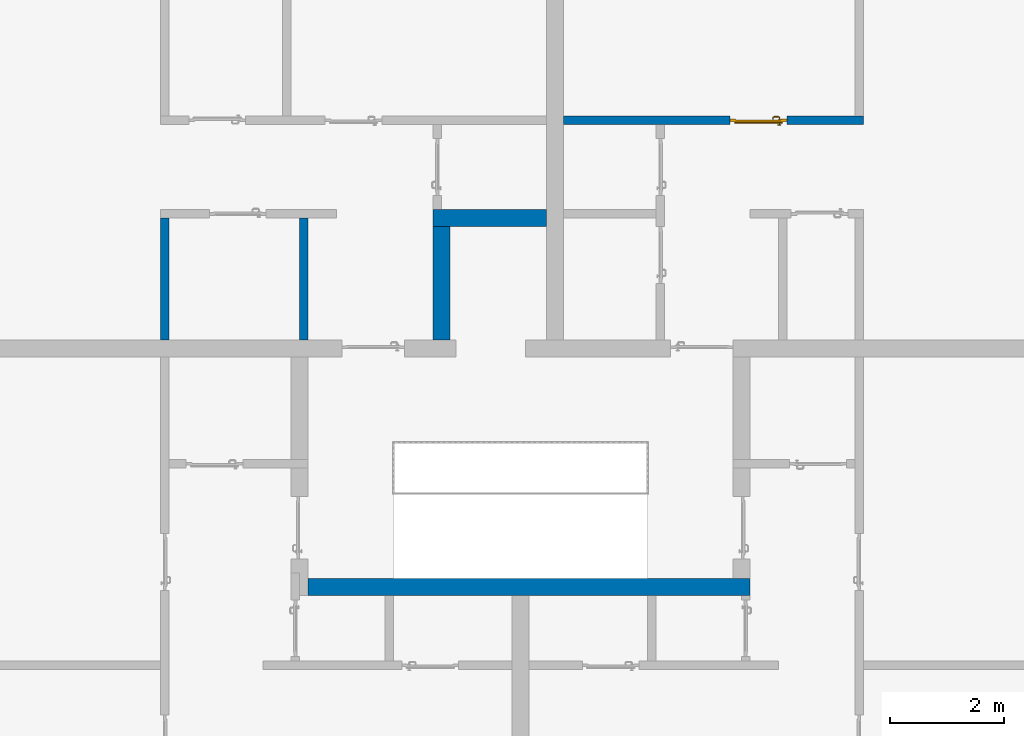
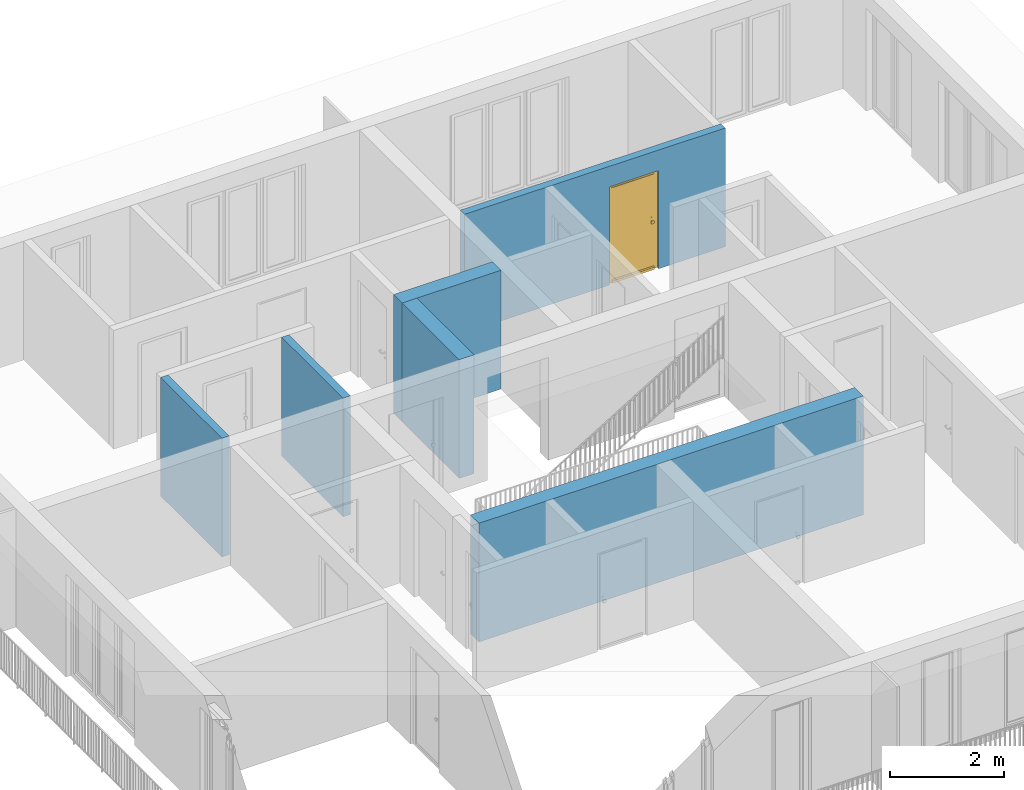
# One storey, part 29 of 54: 6 walls, 1 door, 1 opening.
"""IFC4 building model written with IfcOpenShell, lengths in metres."""

from ifc_helpers import new_model, entity, si_unit, converted_unit, derived_unit, direction, frame, origin_with_axes, place, context, subcontext, project, spatial, polygons, source, transform, mapped, material, type_object, element, fill, save


model = new_model("IFC4")

# Units and contexts
model_context = context("Model", 3, precision=1e-05, world=origin_with_axes(), true_north=direction((0.0, 1.0)))
body_context = subcontext(model_context, "Body", "Model", "MODEL_VIEW")
ifc_project = project(units=[si_unit("LENGTHUNIT", "METRE"), si_unit("AREAUNIT", "SQUARE_METRE"), si_unit("VOLUMEUNIT", "CUBIC_METRE"), converted_unit("PLANEANGLEUNIT", "DEGREE", entity("IfcPlaneAngleMeasure", 0.0174532925199), si_unit("PLANEANGLEUNIT", "RADIAN"), dimensions=[0, 0, 0, 0, 0, 0, 0]), converted_unit("TIMEUNIT", "Year", entity("IfcTimeMeasure", 31556926.0), si_unit("TIMEUNIT", "SECOND"), dimensions=[0, 0, 1, 0, 0, 0, 0]), si_unit("MASSUNIT", "GRAM", prefix="KILO"), si_unit("THERMODYNAMICTEMPERATUREUNIT", "DEGREE_CELSIUS"), si_unit("LUMINOUSINTENSITYUNIT", "LUMEN"), si_unit("ENERGYUNIT", "JOULE", prefix="MEGA"), derived_unit("THERMALCONDUCTANCEUNIT", [(si_unit("POWERUNIT", "WATT"), 1), (si_unit("LENGTHUNIT", "METRE"), -1), (si_unit("THERMODYNAMICTEMPERATUREUNIT", "KELVIN"), -1)]), derived_unit("SPECIFICHEATCAPACITYUNIT", [(si_unit("ENERGYUNIT", "JOULE"), 1), (si_unit("MASSUNIT", "GRAM", prefix="KILO"), -1), (si_unit("THERMODYNAMICTEMPERATUREUNIT", "KELVIN"), -1)]), derived_unit("MASSDENSITYUNIT", [(si_unit("MASSUNIT", "GRAM", prefix="KILO"), 1), (si_unit("VOLUMEUNIT", "CUBIC_METRE"), -1)])], contexts=[model_context])

# Site, building, storey
site_placement = place(None, origin_with_axes())
site = spatial("IfcSite", under=ifc_project, at=site_placement, CompositionType="ELEMENT")
building_placement = place(site_placement, origin_with_axes())
building = spatial("IfcBuilding", under=site, at=building_placement, CompositionType="ELEMENT")
storey_placement = place(building_placement, frame((0.0, 0.0, 6.29), z_axis=(0.0, 0.0, 1.0), x_axis=(1.0, 0.0, 0.0)))
storey = spatial("IfcBuildingStorey", under=building, at=storey_placement, Name="2. Geschoss", CompositionType="ELEMENT", Elevation=6.29)

# Walls
ifc_material = material()
wall_type_1 = type_object("IfcWallType", Name="300", PredefinedType="NOTDEFINED")
wall_1_placement = place(storey_placement, frame((2.8378006196, -2.52881223104, 0.0), z_axis=(0.0, 0.0, 1.0), x_axis=(-1.0, 0.0, 0.0)))
element("IfcWall", 1, at=wall_1_placement, inside=storey, type_object=wall_type_1, material=ifc_material, Name="Wand-001", PredefinedType="NOTDEFINED", context=body_context, shape_type="Tessellation", body=[
    polygons([(7.78, 0.0, 2.54), (6.28, 0.0, 2.54), (1.8, 0.0, 2.54), (0.0, 0.0, 2.54), (0.0, 0.0, 0.0), (7.78, 0.0, 0.0), (7.78, 0.3, 2.54), (0.0, 0.3, 2.54), (0.0, 0.3, 0.0), (7.78, 0.3, 0.0)], [[[1, 2, 3, 4, 5, 6]], [[4, 3, 2, 1, 7, 8]], [[5, 4, 8, 9]], [[5, 9, 10, 6]], [[10, 7, 1, 6]], [[8, 7, 10, 9]]], closed=True),
])
wall_2_placement = place(storey_placement, frame((-2.7421993804, 3.67118776896, 0.0), z_axis=(0.0, 0.0, 1.0), x_axis=(1.0, 0.0, 0.0)))
element("IfcWall", 2, at=wall_2_placement, inside=storey, type_object=wall_type_1, material=ifc_material, Name="Wand-001", PredefinedType="NOTDEFINED", context=body_context, shape_type="Tessellation", body=[
    polygons([(0.0, 0.3, 0.0), (0.0, 0.3, 2.54), (2.0, 0.3, 2.54), (2.0, 0.3, 0.0), (0.0, 0.0, 0.0), (0.0, 0.0, 2.54), (2.0, 0.0, 2.54), (2.0, 0.0, 0.0)], [[[1, 2, 3, 4]], [[5, 6, 2, 1]], [[6, 7, 3, 2]], [[4, 3, 7, 8]], [[5, 1, 4, 8]], [[8, 7, 6, 5]]], closed=True),
])
wall_3_placement = place(storey_placement, frame((-2.7421993804, 1.37118776896, 0.0), z_axis=(0.0, 0.0, 1.0), x_axis=(0.0, 1.0, 0.0)))
element("IfcWall", 3, at=wall_3_placement, inside=storey, type_object=wall_type_1, material=ifc_material, Name="Wand-001", PredefinedType="NOTDEFINED", context=body_context, shape_type="Tessellation", body=[
    polygons([(2.3, 0.0, 0.0), (2.3, 0.0, 2.54), (2.3, -0.3, 2.54), (2.3, -0.3, 0.0), (0.3, 0.0, 0.0), (0.3, 0.0, 2.54), (0.3, -0.3, 2.54), (0.3, -0.3, 0.0)], [[[1, 2, 3, 4]], [[5, 6, 2, 1]], [[6, 7, 3, 2]], [[4, 3, 7, 8]], [[5, 1, 4, 8]], [[8, 7, 6, 5]]], closed=True),
])
wall_type_2 = type_object("IfcWallType", Name="150", PredefinedType="NOTDEFINED")
wall_4_placement = place(storey_placement, frame((-4.9421993804, 1.37118776896, 0.0), z_axis=(0.0, 0.0, 1.0), x_axis=(0.0, 1.0, 0.0)))
element("IfcWall", 4, at=wall_4_placement, inside=storey, type_object=wall_type_2, material=ifc_material, Name="Wand-002", PredefinedType="NOTDEFINED", context=body_context, shape_type="Tessellation", body=[
    polygons([(2.45, 0.15, 0.0), (2.45, 0.15, 2.54), (2.45, 0.0, 2.54), (2.45, 0.0, 0.0), (0.3, 0.15, 0.0), (0.3, 0.15, 2.54), (0.3, 0.0, 2.54), (0.3, 0.0, 0.0)], [[[1, 2, 3, 4]], [[5, 6, 2, 1]], [[6, 7, 3, 2]], [[4, 3, 7, 8]], [[5, 1, 4, 8]], [[8, 7, 6, 5]]], closed=True),
])
wall_5_placement = place(storey_placement, frame((-7.5421993804, 3.97118776896, 0.0), z_axis=(0.0, 0.0, 1.0), x_axis=(0.0, -1.0, 0.0)))
element("IfcWall", 5, at=wall_5_placement, inside=storey, type_object=wall_type_2, material=ifc_material, Name="Wand-003", PredefinedType="NOTDEFINED", context=body_context, shape_type="Tessellation", body=[
    polygons([(0.15, 0.0, 0.0), (0.15, 0.0, 2.54), (0.15, 0.15, 2.54), (0.15, 0.15, 0.0), (2.3, 0.0, 0.0), (2.3, 0.0, 2.54), (2.3, 0.15, 2.54), (2.3, 0.15, 0.0)], [[[1, 2, 3, 4]], [[5, 6, 2, 1]], [[6, 7, 3, 2]], [[4, 3, 7, 8]], [[1, 4, 8, 5]], [[8, 7, 6, 5]]], closed=True),
])

# Wall, opening, door
wall_6_placement = place(storey_placement, frame((-0.742199380397, 5.47118776896, 0.0), z_axis=(0.0, 0.0, 1.0), x_axis=(1.0, 0.0, 0.0)))
wall_6 = element("IfcWall", 6, at=wall_6_placement, inside=storey, type_object=wall_type_2, material=ifc_material, Name="Wand-002", PredefinedType="NOTDEFINED", context=body_context, shape_type="Tessellation", body=[
    polygons([(3.23, 0.15, 2.1), (3.23, 0.15, 0.0), (0.3, 0.15, 0.0), (0.3, 0.15, 2.54), (5.58, 0.15, 2.54), (5.58, 0.15, 0.0), (4.23, 0.15, 0.0), (4.23, 0.15, 2.1), (3.23, 0.05, 2.1), (3.23, 0.05, 0.0), (3.23, 0.0, 0.0), (0.3, 0.0, 0.0), (0.3, 0.0, 2.54), (5.58, 0.0, 2.54), (5.58, 0.0, 0.0), (4.23, 0.05, 0.0), (4.23, 0.0, 0.0), (4.23, 0.05, 2.1), (3.23, 0.0, 2.1), (4.23, 0.0, 2.1)], [[[1, 2, 3, 4, 5, 6, 7, 8]], [[2, 1, 9, 10]], [[2, 10, 11, 12, 3]], [[4, 3, 12, 13]], [[5, 4, 13, 14]], [[14, 15, 6, 5]], [[16, 7, 6, 15, 17]], [[8, 7, 16, 18]], [[1, 8, 18, 9]], [[10, 9, 19, 11]], [[12, 11, 19, 20, 17, 15, 14, 13]], [[18, 16, 17, 20]], [[9, 18, 20, 19]]], closed=True),
])
opening_placement = place(wall_6_placement, frame((3.73, 0.0, 0.0), z_axis=(0.0, 0.0, 1.0), x_axis=(1.0, 0.0, 0.0)))
opening = element("IfcOpeningElement", 7, at=opening_placement, cuts=wall_6, context=body_context, identifier="Reference", shape_type="Tessellation", body=[
    polygons([(0.5, 0.05, 0.0), (0.5, 0.05, 2.1), (0.5, -0.001, 2.1), (0.5, -0.001, 0.0), (0.5, 0.151, 0.0), (0.5, 0.151, 2.1), (-0.5, 0.05, 2.1), (-0.5, -0.001, 2.1), (-0.5, 0.151, 2.1), (-0.5, -0.001, 0.0), (-0.5, 0.05, 0.0), (-0.5, 0.151, 0.0)], [[[1, 2, 3, 4]], [[2, 1, 5, 6]], [[7, 8, 3, 2, 6, 9]], [[8, 10, 4, 3]], [[1, 4, 10, 11, 12, 5]], [[6, 5, 12, 9]], [[7, 11, 10, 8]], [[11, 7, 9, 12]]], closed=True),
])
door_type = type_object("IfcDoorType", Name="Eingang 01 1-Fl 26", OperationType="SINGLE_SWING_RIGHT", PredefinedType="DOOR")
shared_shape = source(origin_with_axes(), body_context, "Body", "Tessellation", [
    polygons([(0.5, -0.05, 0.0), (0.5, -0.03, 0.0), (0.5, -0.03, 2.1), (0.5, -0.05, 2.1), (0.4, -0.05, 0.0), (0.4, -0.03, 0.0), (0.4, -0.03, 2.0), (0.1301, -0.03, 2.0), (0.0001, -0.03, 2.0), (-0.4, -0.03, 2.0), (-0.4, -0.03, 0.0), (-0.5, -0.03, 0.0), (-0.5, -0.03, 2.1), (-0.5, -0.05, 2.1), (-0.5, -0.05, 0.0), (-0.4, -0.05, 0.0), (-0.4, -0.05, 2.0), (0.0001, -0.05, 2.0), (0.1301, -0.05, 2.0), (0.4, -0.05, 2.0)], [[[1, 2, 3, 4]], [[5, 6, 2, 1]], [[2, 6, 7, 8, 9, 10, 11, 12, 13, 3]], [[4, 3, 13, 14]], [[1, 4, 14, 15, 16, 17, 18, 19, 20, 5]], [[20, 7, 6, 5]], [[19, 8, 7, 20]], [[18, 9, 8, 19]], [[17, 10, 9, 18]], [[16, 11, 10, 17]], [[15, 12, 11, 16]], [[14, 13, 12, 15]]], closed=True),
    polygons([(0.5, -0.03, 0.0), (0.5, 0.0, 0.0), (0.5, 0.0, 2.1), (0.5, -0.03, 2.1), (0.43, -0.03, 0.0), (0.43, 0.0, 0.0), (0.43, 0.0, 2.03), (0.1001, 0.0, 2.03), (0.0301, 0.0, 2.03), (-0.43, 0.0, 2.03), (-0.43, 0.0, 0.0), (-0.5, 0.0, 0.0), (-0.5, 0.0, 2.1), (-0.5, -0.03, 2.1), (-0.5, -0.03, 0.0), (-0.43, -0.03, 0.0), (-0.43, -0.03, 2.03), (0.0301, -0.03, 2.03), (0.1001, -0.03, 2.03), (0.43, -0.03, 2.03)], [[[1, 2, 3, 4]], [[5, 6, 2, 1]], [[2, 6, 7, 8, 9, 10, 11, 12, 13, 3]], [[4, 3, 13, 14]], [[1, 4, 14, 15, 16, 17, 18, 19, 20, 5]], [[20, 7, 6, 5]], [[19, 8, 7, 20]], [[18, 9, 8, 19]], [[17, 10, 9, 18]], [[16, 11, 10, 17]], [[15, 12, 11, 16]], [[14, 13, 12, 15]]], closed=True),
    polygons([(0.43, 0.01, 0.0), (-0.43, 0.01, 0.0), (-0.43, 0.01, 2.03), (0.43, 0.01, 2.03), (0.43, -0.03, 0.0), (-0.43, -0.03, 0.0), (-0.43, -0.03, 2.03), (0.43, -0.03, 2.03)], [[[1, 2, 3, 4]], [[2, 1, 5, 6]], [[3, 2, 6, 7]], [[4, 3, 7, 8]], [[1, 4, 8, 5]], [[6, 5, 8, 7]]], closed=True),
    polygons([(0.425, 0.03, 0.0), (-0.425, 0.03, 0.0), (-0.425, 0.03, 0.05), (0.425, 0.03, 0.05), (0.425, 0.01, 0.0), (-0.425, 0.01, 0.0), (-0.425, 0.01, 0.07), (-0.425, 0.015, 0.07), (0.425, 0.015, 0.07), (0.425, 0.01, 0.07)], [[[1, 2, 3, 4]], [[5, 6, 2, 1]], [[2, 6, 7, 8, 3]], [[4, 3, 8, 9]], [[1, 4, 9, 10, 5]], [[10, 7, 6, 5]], [[9, 8, 7, 10]]], closed=True),
    polygons([(-0.3835, -0.04, 1.0733826859), (-0.37, -0.04, 1.077), (-0.37, -0.0399, 1.077), (-0.3835, -0.0399, 1.0733826859), (-0.393382685902, -0.04, 1.0635), (-0.397, -0.04, 1.05), (-0.393382685902, -0.04, 1.0365), (-0.3835, -0.04, 1.0266173141), (-0.37, -0.04, 1.023), (-0.3565, -0.04, 1.0266173141), (-0.346617314098, -0.04, 1.0365), (-0.343, -0.04, 1.05), (-0.346617314098, -0.04, 1.0635), (-0.3565, -0.04, 1.0733826859), (-0.3565, -0.0399, 1.0733826859), (-0.37, -0.0301, 1.077), (-0.3835, -0.0301, 1.0733826859), (-0.393382685902, -0.0399, 1.0635), (-0.397, -0.0399, 1.05), (-0.393382685902, -0.0399, 1.0365), (-0.3835, -0.0399, 1.0266173141), (-0.37, -0.0399, 1.023), (-0.3565, -0.0399, 1.0266173141), (-0.346617314098, -0.0399, 1.0365), (-0.343, -0.0399, 1.05), (-0.346617314098, -0.0399, 1.0635), (-0.3565, -0.0301, 1.0733826859), (-0.37, -0.03, 1.077), (-0.3835, -0.03, 1.0733826859), (-0.393382685902, -0.0301, 1.0635), (-0.397, -0.0301, 1.05), (-0.393382685902, -0.0301, 1.0365), (-0.3835, -0.0301, 1.0266173141), (-0.37, -0.0301, 1.023), (-0.3565, -0.0301, 1.0266173141), (-0.346617314098, -0.0301, 1.0365), (-0.343, -0.0301, 1.05), (-0.346617314098, -0.0301, 1.0635), (-0.3565, -0.03, 1.0733826859), (-0.346617314098, -0.03, 1.0635), (-0.343, -0.03, 1.05), (-0.346617314098, -0.03, 1.0365), (-0.3565, -0.03, 1.0266173141), (-0.37, -0.03, 1.023), (-0.3835, -0.03, 1.0266173141), (-0.393382685902, -0.03, 1.0365), (-0.397, -0.03, 1.05), (-0.393382685902, -0.03, 1.0635)], [[[1, 2, 3, 4]], [[2, 1, 5, 6, 7, 8, 9, 10, 11, 12, 13, 14]], [[2, 14, 15, 3]], [[4, 3, 16, 17]], [[5, 1, 4, 18]], [[6, 5, 18, 19]], [[7, 6, 19, 20]], [[8, 7, 20, 21]], [[9, 8, 21, 22]], [[10, 9, 22, 23]], [[11, 10, 23, 24]], [[12, 11, 24, 25]], [[13, 12, 25, 26]], [[14, 13, 26, 15]], [[3, 15, 27, 16]], [[17, 16, 28, 29]], [[18, 4, 17, 30]], [[19, 18, 30, 31]], [[20, 19, 31, 32]], [[21, 20, 32, 33]], [[22, 21, 33, 34]], [[23, 22, 34, 35]], [[24, 23, 35, 36]], [[25, 24, 36, 37]], [[26, 25, 37, 38]], [[15, 26, 38, 27]], [[16, 27, 39, 28]], [[28, 39, 40, 41, 42, 43, 44, 45, 46, 47, 48, 29]], [[30, 17, 29, 48]], [[31, 30, 48, 47]], [[32, 31, 47, 46]], [[33, 32, 46, 45]], [[34, 33, 45, 44]], [[35, 34, 44, 43]], [[36, 35, 43, 42]], [[37, 36, 42, 41]], [[38, 37, 41, 40]], [[27, 38, 40, 39]]], closed=True),
    polygons([(-0.362532169224, -0.04, 0.959692280177), (-0.365, -0.04, 0.9544), (-0.365, -0.04, 0.952886751346), (-0.346703916638, -0.04, 0.96345), (-0.35655, -0.04, 0.973296083362), (-0.363279754556, -0.04, 0.961639806549), (-0.362532169224, -0.039, 0.959692280177), (-0.365, -0.039, 0.9544), (-0.365, -0.039, 0.952886751346), (-0.365, -0.039, 0.95), (-0.365, -0.039, 0.947113248654), (-0.365, -0.039, 0.941339745962), (-0.365, -0.039, 0.9375), (-0.365, -0.04, 0.9375), (-0.365, -0.04, 0.941339745962), (-0.365, -0.04, 0.947113248654), (-0.365, -0.04, 0.95), (-0.3431, -0.04, 0.95), (-0.346617314098, -0.04, 0.9635), (-0.3565, -0.04, 0.973382685902), (-0.364624817685, -0.04, 0.965143815798), (-0.37, -0.04, 0.9769), (-0.37, -0.04, 0.967425445323), (-0.364624817685, -0.039, 0.965143815798), (-0.363279754556, -0.039, 0.961639806549), (-0.35705, -0.039, 0.972430057958), (-0.347569942042, -0.039, 0.96295), (-0.3441, -0.039, 0.95), (-0.347569942042, -0.039, 0.93705), (-0.35705, -0.039, 0.927569942042), (-0.37, -0.039, 0.9241), (-0.37, -0.039, 0.9325), (-0.366464466094, -0.039, 0.933964466094), (-0.366464466094, -0.04, 0.933964466094), (-0.35655, -0.04, 0.926703916638), (-0.37, -0.04, 0.9325), (-0.37, -0.04, 0.9231), (-0.346703916638, -0.04, 0.93655), (-0.343, -0.04, 0.95), (-0.346617314098, -0.0399, 0.9635), (-0.3565, -0.0399, 0.973382685902), (-0.37, -0.04, 0.977), (-0.375375182315, -0.04, 0.965143815798), (-0.38345, -0.04, 0.973296083362), (-0.376720245444, -0.04, 0.961639806549), (-0.37, -0.039, 0.967425445323), (-0.37, -0.039, 0.9759), (-0.357, -0.039, 0.972516660498), (-0.347483339502, -0.039, 0.963), (-0.344, -0.039, 0.95), (-0.347483339502, -0.039, 0.937), (-0.357, -0.039, 0.927483339502), (-0.38295, -0.039, 0.927569942042), (-0.375, -0.039, 0.941339745962), (-0.375, -0.039, 0.9375), (-0.373535533906, -0.039, 0.933964466094), (-0.37, -0.039, 0.924), (-0.373535533906, -0.04, 0.933964466094), (-0.375, -0.04, 0.9375), (-0.375, -0.04, 0.941339745962), (-0.38345, -0.04, 0.926703916638), (-0.37, -0.04, 0.923), (-0.3565, -0.04, 0.926617314098), (-0.346617314098, -0.04, 0.9365), (-0.343, -0.0399, 0.95), (-0.346617314098, -0.0301, 0.9635), (-0.3565, -0.0301, 0.973382685902), (-0.37, -0.0399, 0.977), (-0.3835, -0.04, 0.973382685902), (-0.375375182315, -0.039, 0.965143815798), (-0.377467830776, -0.04, 0.959692280177), (-0.393296083362, -0.04, 0.96345), (-0.375, -0.04, 0.952886751346), (-0.375, -0.04, 0.9544), (-0.377467830776, -0.039, 0.959692280177), (-0.376720245444, -0.039, 0.961639806549), (-0.38295, -0.039, 0.972430057958), (-0.37, -0.039, 0.976), (-0.357, -0.0389, 0.972516660498), (-0.347483339502, -0.0389, 0.963), (-0.344, -0.0389, 0.95), (-0.347483339502, -0.0389, 0.937), (-0.357, -0.0389, 0.927483339502), (-0.392430057958, -0.039, 0.93705), (-0.375, -0.039, 0.947113248654), (-0.375, -0.039, 0.9544), (-0.375, -0.04, 0.95), (-0.375, -0.04, 0.947113248654), (-0.375, -0.039, 0.95), (-0.375, -0.039, 0.952886751346), (-0.383, -0.039, 0.927483339502), (-0.37, -0.0389, 0.924), (-0.393296083362, -0.04, 0.93655), (-0.3835, -0.04, 0.926617314098), (-0.37, -0.0399, 0.923), (-0.3565, -0.0399, 0.926617314098), (-0.346617314098, -0.0399, 0.9365), (-0.343, -0.0301, 0.95), (-0.346617314098, -0.03, 0.9635), (-0.3565, -0.03, 0.973382685902), (-0.37, -0.0301, 0.977), (-0.3835, -0.0399, 0.973382685902), (-0.393382685902, -0.04, 0.9635), (-0.3969, -0.04, 0.95), (-0.392430057958, -0.039, 0.96295), (-0.383, -0.039, 0.972516660498), (-0.37, -0.0389, 0.976), (-0.357, -0.0301, 0.972516660498), (-0.347483339502, -0.0301, 0.963), (-0.344, -0.0301, 0.95), (-0.347483339502, -0.0301, 0.937), (-0.357, -0.0301, 0.927483339502), (-0.392516660498, -0.039, 0.937), (-0.3959, -0.039, 0.95), (-0.383, -0.0389, 0.927483339502), (-0.37, -0.0301, 0.924), (-0.393382685902, -0.04, 0.9365), (-0.3835, -0.0399, 0.926617314098), (-0.37, -0.0301, 0.923), (-0.3565, -0.0301, 0.926617314098), (-0.346617314098, -0.0301, 0.9365), (-0.343, -0.03, 0.95), (-0.346703916638, -0.03, 0.96345), (-0.35655, -0.03, 0.973296083362), (-0.37, -0.03, 0.977), (-0.3835, -0.0301, 0.973382685902), (-0.393382685902, -0.0399, 0.9635), (-0.397, -0.04, 0.95), (-0.392516660498, -0.039, 0.963), (-0.383, -0.0389, 0.972516660498), (-0.37, -0.0301, 0.976), (-0.357, -0.03, 0.972516660498), (-0.347483339502, -0.03, 0.963), (-0.344, -0.03, 0.95), (-0.347483339502, -0.03, 0.937), (-0.357, -0.03, 0.927483339502), (-0.392516660498, -0.0389, 0.937), (-0.396, -0.039, 0.95), (-0.383, -0.0301, 0.927483339502), (-0.37, -0.03, 0.924), (-0.393382685902, -0.0399, 0.9365), (-0.3835, -0.0301, 0.926617314098), (-0.37, -0.03, 0.923), (-0.3565, -0.03, 0.926617314098), (-0.346617314098, -0.03, 0.9365), (-0.3431, -0.03, 0.95), (-0.347396736961, -0.03, 0.96305), (-0.35695, -0.03, 0.972603263039), (-0.37, -0.03, 0.9769), (-0.3835, -0.03, 0.973382685902), (-0.393382685902, -0.0301, 0.9635), (-0.397, -0.0399, 0.95), (-0.392516660498, -0.0389, 0.963), (-0.383, -0.0301, 0.972516660498), (-0.37, -0.03, 0.976), (-0.3439, -0.03, 0.95), (-0.347396736961, -0.03, 0.93695), (-0.35695, -0.03, 0.927396736961), (-0.392516660498, -0.0301, 0.937), (-0.396, -0.0389, 0.95), (-0.383, -0.03, 0.927483339502), (-0.37, -0.03, 0.9239), (-0.393382685902, -0.0301, 0.9365), (-0.3835, -0.03, 0.926617314098), (-0.37, -0.03, 0.9231), (-0.35655, -0.03, 0.926703916638), (-0.346703916638, -0.03, 0.93655), (-0.37, -0.03, 0.9761), (-0.38345, -0.03, 0.973296083362), (-0.393382685902, -0.03, 0.9635), (-0.397, -0.0301, 0.95), (-0.392516660498, -0.0301, 0.963), (-0.383, -0.03, 0.972516660498), (-0.392516660498, -0.03, 0.937), (-0.396, -0.0301, 0.95), (-0.38305, -0.03, 0.927396736961), (-0.393382685902, -0.03, 0.9365), (-0.38345, -0.03, 0.926703916638), (-0.38305, -0.03, 0.972603263039), (-0.393296083362, -0.03, 0.96345), (-0.397, -0.03, 0.95), (-0.392516660498, -0.03, 0.963), (-0.392603263039, -0.03, 0.93695), (-0.396, -0.03, 0.95), (-0.393296083362, -0.03, 0.93655), (-0.392603263039, -0.03, 0.96305), (-0.3969, -0.03, 0.95), (-0.3961, -0.03, 0.95)], [[[1, 2, 3, 4, 5, 6]], [[2, 1, 7, 8]], [[2, 8, 9, 10, 11, 12, 13, 14, 15, 16, 17, 3]], [[17, 18, 4, 3]], [[19, 20, 5, 4]], [[21, 6, 5, 22, 23]], [[1, 6, 21, 24, 25, 7]], [[7, 25, 26, 27, 9, 8]], [[9, 27, 28, 10]], [[10, 28, 29, 11]], [[11, 29, 30, 12]], [[31, 32, 33, 13, 12, 30]], [[14, 13, 33, 34]], [[35, 15, 14, 34, 36, 37]], [[15, 35, 38, 16]], [[16, 38, 18, 17]], [[39, 19, 4, 18]], [[40, 41, 20, 19]], [[20, 42, 22, 5]], [[43, 23, 22, 44, 45]], [[21, 23, 46, 24]], [[24, 46, 47, 26, 25]], [[27, 26, 48, 49]], [[28, 27, 49, 50]], [[29, 28, 50, 51]], [[30, 29, 51, 52]], [[53, 54, 55, 56, 32, 31]], [[34, 33, 32, 36]], [[31, 30, 52, 57]], [[37, 36, 58, 59, 60, 61]], [[62, 63, 35, 37]], [[63, 64, 38, 35]], [[64, 39, 18, 38]], [[65, 40, 19, 39]], [[66, 67, 41, 40]], [[41, 68, 42, 20]], [[42, 69, 44, 22]], [[23, 43, 70, 46]], [[71, 45, 44, 72, 73, 74]], [[43, 45, 71, 75, 76, 70]], [[70, 76, 77, 47, 46]], [[26, 47, 78, 48]], [[49, 48, 79, 80]], [[50, 49, 80, 81]], [[51, 50, 81, 82]], [[52, 51, 82, 83]], [[54, 53, 84, 85]], [[86, 74, 73, 87, 88, 60, 59, 55, 54, 85, 89, 90]], [[58, 56, 55, 59]], [[36, 32, 56, 58]], [[53, 31, 57, 91]], [[57, 52, 83, 92]], [[88, 93, 61, 60]], [[94, 62, 37, 61]], [[95, 96, 63, 62]], [[96, 97, 64, 63]], [[97, 65, 39, 64]], [[98, 66, 40, 65]], [[99, 100, 67, 66]], [[67, 101, 68, 41]], [[68, 102, 69, 42]], [[69, 103, 72, 44]], [[73, 72, 104, 87]], [[71, 74, 86, 75]], [[75, 86, 90, 105, 77, 76]], [[47, 77, 106, 78]], [[48, 78, 107, 79]], [[80, 79, 108, 109]], [[81, 80, 109, 110]], [[82, 81, 110, 111]], [[83, 82, 111, 112]], [[84, 53, 91, 113]], [[85, 84, 114, 89]], [[87, 104, 93, 88]], [[89, 114, 105, 90]], [[91, 57, 92, 115]], [[92, 83, 112, 116]], [[117, 94, 61, 93]], [[118, 95, 62, 94]], [[119, 120, 96, 95]], [[120, 121, 97, 96]], [[121, 98, 65, 97]], [[122, 99, 66, 98]], [[123, 124, 100, 99]], [[100, 125, 101, 67]], [[101, 126, 102, 68]], [[102, 127, 103, 69]], [[103, 128, 104, 72]], [[77, 105, 129, 106]], [[78, 106, 130, 107]], [[79, 107, 131, 108]], [[109, 108, 132, 133]], [[110, 109, 133, 134]], [[111, 110, 134, 135]], [[112, 111, 135, 136]], [[113, 91, 115, 137]], [[114, 84, 113, 138]], [[128, 117, 93, 104]], [[105, 114, 138, 129]], [[115, 92, 116, 139]], [[116, 112, 136, 140]], [[141, 118, 94, 117]], [[142, 119, 95, 118]], [[143, 144, 120, 119]], [[144, 145, 121, 120]], [[145, 122, 98, 121]], [[146, 123, 99, 122]], [[147, 148, 124, 123]], [[124, 149, 125, 100]], [[125, 150, 126, 101]], [[126, 151, 127, 102]], [[127, 152, 128, 103]], [[106, 129, 153, 130]], [[107, 130, 154, 131]], [[108, 131, 155, 132]], [[133, 132, 148, 147]], [[134, 133, 147, 156]], [[135, 134, 156, 157]], [[136, 135, 157, 158]], [[137, 115, 139, 159]], [[138, 113, 137, 160]], [[152, 141, 117, 128]], [[129, 138, 160, 153]], [[139, 116, 140, 161]], [[140, 136, 158, 162]], [[163, 142, 118, 141]], [[164, 143, 119, 142]], [[165, 166, 144, 143]], [[166, 167, 145, 144]], [[167, 146, 122, 145]], [[156, 147, 123, 146]], [[148, 168, 149, 124]], [[149, 169, 150, 125]], [[150, 170, 151, 126]], [[151, 171, 152, 127]], [[130, 153, 172, 154]], [[131, 154, 173, 155]], [[132, 155, 168, 148]], [[157, 156, 146, 167]], [[158, 157, 167, 166]], [[159, 139, 161, 174]], [[160, 137, 159, 175]], [[171, 163, 141, 152]], [[153, 160, 175, 172]], [[161, 140, 162, 176]], [[162, 158, 166, 165]], [[177, 164, 142, 163]], [[178, 165, 143, 164]], [[168, 179, 169, 149]], [[169, 180, 170, 150]], [[170, 181, 171, 151]], [[154, 172, 182, 173]], [[155, 173, 179, 168]], [[174, 161, 176, 183]], [[175, 159, 174, 184]], [[181, 177, 163, 171]], [[172, 175, 184, 182]], [[176, 162, 165, 178]], [[185, 178, 164, 177]], [[179, 186, 180, 169]], [[180, 187, 181, 170]], [[173, 182, 186, 179]], [[183, 176, 178, 185]], [[184, 174, 183, 188]], [[187, 185, 177, 181]], [[182, 184, 188, 186]], [[186, 188, 187, 180]], [[188, 183, 185, 187]]], closed=True),
    polygons([(-0.38, -0.04, 1.05), (-0.377071067812, -0.04, 1.04292893219), (-0.377071067812, -0.070696439392, 1.04292893219), (-0.38, -0.0709849140336, 1.05), (-0.37, -0.04, 1.04), (-0.37, -0.07, 1.04), (-0.375518993221, -0.0784992452783, 1.04292893219), (-0.378277987014, -0.0796420579258, 1.05), (-0.377071067812, -0.04, 1.05707106781), (-0.377071067812, -0.070696439392, 1.05707106781), (-0.362928932188, -0.04, 1.04292893219), (-0.362928932188, -0.069303560608, 1.04292893219), (-0.368858192988, -0.0757402514855, 1.04), (-0.370704557509, -0.0857045575088, 1.04292893219), (-0.372816199938, -0.0878161999379, 1.05), (-0.375518993221, -0.0784992452783, 1.05707106781), (-0.37, -0.04, 1.06), (-0.37, -0.07, 1.06), (-0.36, -0.04, 1.05), (-0.36, -0.0690150859664, 1.05), (-0.362197392755, -0.0729812576926, 1.04292893219), (-0.365606601718, -0.0806066017178, 1.04), (-0.363499245278, -0.0905189932208, 1.04292893219), (-0.364642057926, -0.0932779870137, 1.05), (-0.370704557509, -0.0857045575088, 1.05707106781), (-0.368858192988, -0.0757402514855, 1.06), (-0.362928932188, -0.04, 1.05707106781), (-0.362928932188, -0.069303560608, 1.05707106781), (-0.359438398962, -0.0718384450452, 1.05), (-0.360508645927, -0.0755086459268, 1.04292893219), (-0.360740251485, -0.0838581929877, 1.04), (-0.355696439392, -0.0920710678119, 1.04292893219), (-0.355984914034, -0.095, 1.05), (-0.363499245278, -0.0905189932208, 1.05707106781), (-0.365606601718, -0.0806066017178, 1.06), (-0.362197392755, -0.0729812576926, 1.05707106781), (-0.358397003498, -0.0733970034977, 1.05), (-0.357981257693, -0.0771973927545, 1.04292893219), (-0.355, -0.085, 1.04), (-0.274303560608, -0.0920710678119, 1.04292893219), (-0.274015085966, -0.095, 1.05), (-0.355696439392, -0.0920710678119, 1.05707106781), (-0.360740251485, -0.0838581929877, 1.06), (-0.360508645927, -0.0755086459268, 1.05707106781), (-0.356838445045, -0.0744383989617, 1.05), (-0.354303560608, -0.0779289321881, 1.04292893219), (-0.275, -0.085, 1.04), (-0.266500754722, -0.0905189932208, 1.04292893219), (-0.265357942074, -0.0932779870137, 1.05), (-0.274303560608, -0.0920710678119, 1.05707106781), (-0.355, -0.085, 1.06), (-0.357981257693, -0.0771973927545, 1.05707106781), (-0.354015085966, -0.075, 1.05), (-0.275696439392, -0.0779289321881, 1.04292893219), (-0.269259748515, -0.0838581929877, 1.04), (-0.259295442491, -0.0857045575088, 1.04292893219), (-0.257183800062, -0.0878161999379, 1.05), (-0.266500754722, -0.0905189932208, 1.05707106781), (-0.275, -0.085, 1.06), (-0.354303560608, -0.0779289321881, 1.05707106781), (-0.275984914034, -0.075, 1.05), (-0.272018742307, -0.0771973927545, 1.04292893219), (-0.264393398282, -0.0806066017178, 1.04), (-0.254481006779, -0.0784992452783, 1.04292893219), (-0.251722012986, -0.0796420579258, 1.05), (-0.259295442491, -0.0857045575088, 1.05707106781), (-0.269259748515, -0.0838581929877, 1.06), (-0.275696439392, -0.0779289321881, 1.05707106781), (-0.273161554955, -0.0744383989617, 1.05), (-0.269491354073, -0.0755086459268, 1.04292893219), (-0.261141807012, -0.0757402514855, 1.04), (-0.252928932188, -0.070696439392, 1.04292893219), (-0.25, -0.0709849140336, 1.05), (-0.254481006779, -0.0784992452783, 1.05707106781), (-0.264393398282, -0.0806066017178, 1.06), (-0.272018742307, -0.0771973927545, 1.05707106781), (-0.271602996502, -0.0733970034977, 1.05), (-0.267802607245, -0.0729812576926, 1.04292893219), (-0.26, -0.07, 1.04), (-0.252928932188, -0.04, 1.04292893219), (-0.25, -0.04, 1.05), (-0.252928932188, -0.070696439392, 1.05707106781), (-0.261141807012, -0.0757402514855, 1.06), (-0.269491354073, -0.0755086459268, 1.05707106781), (-0.270561601038, -0.0718384450452, 1.05), (-0.267071067812, -0.069303560608, 1.04292893219), (-0.26, -0.04, 1.04), (-0.267071067812, -0.04, 1.04292893219), (-0.27, -0.04, 1.05), (-0.267071067812, -0.04, 1.05707106781), (-0.26, -0.04, 1.06), (-0.252928932188, -0.04, 1.05707106781), (-0.26, -0.07, 1.06), (-0.267802607245, -0.0729812576926, 1.05707106781), (-0.27, -0.0690150859664, 1.05), (-0.267071067812, -0.069303560608, 1.05707106781)], [[[1, 2, 3, 4]], [[2, 5, 6, 3]], [[4, 3, 7, 8]], [[9, 1, 4, 10]], [[5, 11, 12, 6]], [[3, 6, 13, 7]], [[8, 7, 14, 15]], [[10, 4, 8, 16]], [[17, 9, 10, 18]], [[11, 19, 20, 12]], [[6, 12, 21, 13]], [[7, 13, 22, 14]], [[15, 14, 23, 24]], [[16, 8, 15, 25]], [[18, 10, 16, 26]], [[27, 17, 18, 28]], [[19, 27, 28, 20]], [[12, 20, 29, 21]], [[13, 21, 30, 22]], [[14, 22, 31, 23]], [[24, 23, 32, 33]], [[25, 15, 24, 34]], [[26, 16, 25, 35]], [[28, 18, 26, 36]], [[20, 28, 36, 29]], [[21, 29, 37, 30]], [[22, 30, 38, 31]], [[23, 31, 39, 32]], [[33, 32, 40, 41]], [[34, 24, 33, 42]], [[35, 25, 34, 43]], [[36, 26, 35, 44]], [[29, 36, 44, 37]], [[30, 37, 45, 38]], [[31, 38, 46, 39]], [[32, 39, 47, 40]], [[41, 40, 48, 49]], [[42, 33, 41, 50]], [[43, 34, 42, 51]], [[44, 35, 43, 52]], [[37, 44, 52, 45]], [[38, 45, 53, 46]], [[39, 46, 54, 47]], [[40, 47, 55, 48]], [[49, 48, 56, 57]], [[50, 41, 49, 58]], [[51, 42, 50, 59]], [[52, 43, 51, 60]], [[45, 52, 60, 53]], [[46, 53, 61, 54]], [[47, 54, 62, 55]], [[48, 55, 63, 56]], [[57, 56, 64, 65]], [[58, 49, 57, 66]], [[59, 50, 58, 67]], [[60, 51, 59, 68]], [[53, 60, 68, 61]], [[54, 61, 69, 62]], [[55, 62, 70, 63]], [[56, 63, 71, 64]], [[65, 64, 72, 73]], [[66, 57, 65, 74]], [[67, 58, 66, 75]], [[68, 59, 67, 76]], [[61, 68, 76, 69]], [[62, 69, 77, 70]], [[63, 70, 78, 71]], [[64, 71, 79, 72]], [[73, 72, 80, 81]], [[74, 65, 73, 82]], [[75, 66, 74, 83]], [[76, 67, 75, 84]], [[69, 76, 84, 77]], [[70, 77, 85, 78]], [[71, 78, 86, 79]], [[72, 79, 87, 80]], [[81, 80, 87, 88, 89, 90, 91, 92]], [[82, 73, 81, 92]], [[83, 74, 82, 93]], [[84, 75, 83, 94]], [[77, 84, 94, 85]], [[78, 85, 95, 86]], [[79, 86, 88, 87]], [[86, 95, 89, 88]], [[95, 96, 90, 89]], [[96, 93, 91, 90]], [[93, 82, 92, 91]], [[94, 83, 93, 96]], [[85, 94, 96, 95]]], closed=False),
    polygons([(-0.364696699141, 0.015, 1.04469669914), (-0.3625, 0.015, 1.05), (-0.364696699141, 0.015, 1.05530330086), (-0.37, 0.015, 1.0575), (-0.375303300859, 0.015, 1.05530330086), (-0.3775, 0.015, 1.05), (-0.375303300859, 0.015, 1.04469669914), (-0.37, 0.015, 1.0425), (-0.364696699141, 0.055, 1.04469669914), (-0.3625, 0.055, 1.05), (-0.364696699141, 0.055, 1.05530330086), (-0.37, 0.055, 1.0575), (-0.375303300859, 0.055, 1.05530330086), (-0.3775, 0.055, 1.05), (-0.375303300859, 0.055, 1.04469669914), (-0.37, 0.055, 1.0425)], [[[1, 2, 3, 4, 5, 6, 7, 8]], [[1, 9, 10, 2]], [[2, 10, 11, 3]], [[3, 11, 12, 4]], [[4, 12, 13, 5]], [[5, 13, 14, 6]], [[6, 14, 15, 7]], [[7, 15, 16, 8]], [[8, 16, 9, 1]], [[9, 16, 15, 14, 13, 12, 11, 10]]], closed=True),
    polygons([(-0.395, 0.01, 0.975), (-0.395, 0.015, 0.975), (-0.393096988313, 0.015, 0.965432914191), (-0.393096988313, 0.01, 0.965432914191), (-0.395, 0.01, 1.1), (-0.395, 0.015, 1.1), (-0.393096988313, 0.015, 1.10956708581), (-0.38767766953, 0.015, 1.11767766953), (-0.379567085809, 0.015, 1.12309698831), (-0.37, 0.015, 1.125), (-0.360432914191, 0.015, 1.12309698831), (-0.35232233047, 0.015, 1.11767766953), (-0.346903011687, 0.015, 1.10956708581), (-0.345, 0.015, 1.1), (-0.345, 0.015, 0.975), (-0.346903011687, 0.015, 0.965432914191), (-0.35232233047, 0.015, 0.95732233047), (-0.360432914191, 0.015, 0.951903011687), (-0.37, 0.015, 0.95), (-0.379567085809, 0.015, 0.951903011687), (-0.38767766953, 0.015, 0.95732233047), (-0.38767766953, 0.01, 0.95732233047), (-0.379567085809, 0.01, 0.951903011687), (-0.37, 0.01, 0.95), (-0.360432914191, 0.01, 0.951903011687), (-0.35232233047, 0.01, 0.95732233047), (-0.346903011687, 0.01, 0.965432914191), (-0.345, 0.01, 0.975), (-0.345, 0.01, 1.1), (-0.346903011687, 0.01, 1.10956708581), (-0.35232233047, 0.01, 1.11767766953), (-0.360432914191, 0.01, 1.12309698831), (-0.37, 0.01, 1.125), (-0.379567085809, 0.01, 1.12309698831), (-0.38767766953, 0.01, 1.11767766953), (-0.393096988313, 0.01, 1.10956708581)], [[[1, 2, 3, 4]], [[5, 6, 2, 1]], [[2, 6, 7, 8, 9, 10, 11, 12, 13, 14, 15, 16, 17, 18, 19, 20, 21, 3]], [[4, 3, 21, 22]], [[1, 4, 22, 23, 24, 25, 26, 27, 28, 29, 30, 31, 32, 33, 34, 35, 36, 5]], [[36, 7, 6, 5]], [[35, 8, 7, 36]], [[34, 9, 8, 35]], [[33, 10, 9, 34]], [[32, 11, 10, 33]], [[31, 12, 11, 32]], [[30, 13, 12, 31]], [[29, 14, 13, 30]], [[28, 15, 14, 29]], [[27, 16, 15, 28]], [[26, 17, 16, 27]], [[25, 18, 17, 26]], [[24, 19, 18, 25]], [[23, 20, 19, 24]], [[22, 21, 20, 23]]], closed=True),
    polygons([(-0.39, 0.055, 1.08), (-0.39, 0.07, 1.08), (-0.395, 0.07, 1.07866025404), (-0.395, 0.055, 1.07866025404), (-0.35, 0.055, 1.08), (-0.35, 0.07, 1.08), (-0.345, 0.07, 1.07866025404), (-0.341339745962, 0.07, 1.075), (-0.34, 0.07, 1.07), (-0.34, 0.07, 1.03), (-0.341339745962, 0.07, 1.025), (-0.345, 0.07, 1.02133974596), (-0.35, 0.07, 1.02), (-0.39, 0.07, 1.02), (-0.395, 0.07, 1.02133974596), (-0.398660254038, 0.07, 1.025), (-0.4, 0.07, 1.03), (-0.4, 0.07, 1.07), (-0.398660254038, 0.07, 1.075), (-0.398660254038, 0.055, 1.075), (-0.4, 0.055, 1.07), (-0.4, 0.055, 1.03), (-0.398660254038, 0.055, 1.025), (-0.395, 0.055, 1.02133974596), (-0.39, 0.055, 1.02), (-0.35, 0.055, 1.02), (-0.345, 0.055, 1.02133974596), (-0.341339745962, 0.055, 1.025), (-0.34, 0.055, 1.03), (-0.34, 0.055, 1.07), (-0.341339745962, 0.055, 1.075), (-0.345, 0.055, 1.07866025404)], [[[1, 2, 3, 4]], [[5, 6, 2, 1]], [[2, 6, 7, 8, 9, 10, 11, 12, 13, 14, 15, 16, 17, 18, 19, 3]], [[4, 3, 19, 20]], [[1, 4, 20, 21, 22, 23, 24, 25, 26, 27, 28, 29, 30, 31, 32, 5]], [[32, 7, 6, 5]], [[31, 8, 7, 32]], [[30, 9, 8, 31]], [[29, 10, 9, 30]], [[28, 11, 10, 29]], [[27, 12, 11, 28]], [[26, 13, 12, 27]], [[25, 14, 13, 26]], [[24, 15, 14, 25]], [[23, 16, 15, 24]], [[22, 17, 16, 23]], [[21, 18, 17, 22]], [[20, 19, 18, 21]]], closed=True),
])
door_placement = place(opening_placement, frame((0.4, 0.0, 0.0), z_axis=(0.0, 0.0, 1.0), x_axis=(-1.0, 0.0, 0.0)))
door = element("IfcDoor", 8, at=door_placement, inside=storey, type_object=door_type, OverallHeight=2.1, OverallWidth=1.0, PredefinedType="DOOR", context=body_context, shape_type="MappedRepresentation", body=[
    mapped(shared_shape, transform((0.4, -0.05, 0.0))),
])
fill(opening, door)

save(model, "model.ifc")
